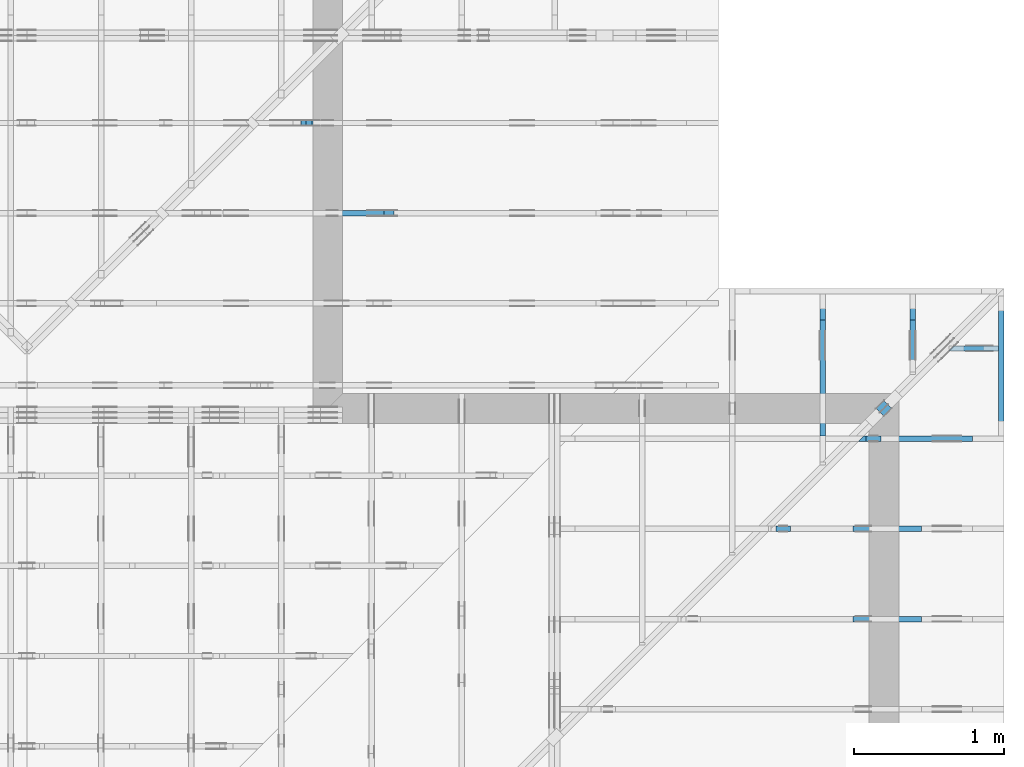
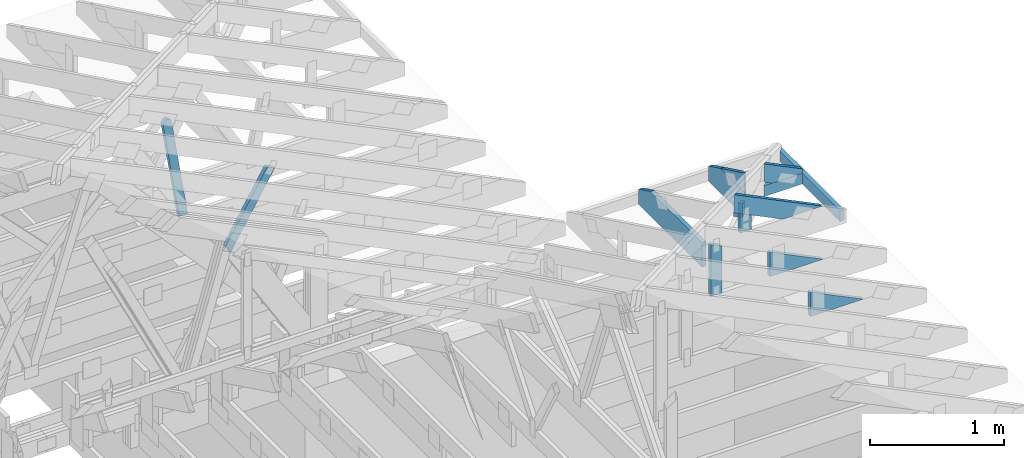
# One storey, part 51 of 159: 15 members, 10 elements without a shape of their own.
"""IFC2X3 building model written with IfcOpenShell, lengths in millimetres."""

from ifc_helpers import new_model, si_unit, frame, origin, origin_with_axes, origin_2d, place, context, project, spatial, faceted_brep, element, aggregate, save


model = new_model("IFC2X3")

# Units and contexts
model_context = context("Model", 3, precision=1e-05, world=origin())
plan_context = context("Plan", 2, precision=1e-05, world=origin_2d())
ifc_project = project(units=[si_unit("LENGTHUNIT", "METRE", prefix="MILLI"), si_unit("AREAUNIT", "SQUARE_METRE"), si_unit("VOLUMEUNIT", "CUBIC_METRE"), si_unit("SOLIDANGLEUNIT", "STERADIAN"), si_unit("PLANEANGLEUNIT", "RADIAN"), si_unit("MASSUNIT", "GRAM"), si_unit("TIMEUNIT", "SECOND"), si_unit("THERMODYNAMICTEMPERATUREUNIT", "DEGREE_CELSIUS"), si_unit("LUMINOUSINTENSITYUNIT", "LUMEN")], contexts=[model_context, plan_context])

# Site, building, storey
site_placement = place(None, origin_with_axes())
site = spatial("IfcSite", under=ifc_project, at=site_placement, CompositionType="ELEMENT")
building_placement = place(site_placement, origin_with_axes())
building = spatial("IfcBuilding", under=site, at=building_placement, Name="Plan 1", CompositionType="ELEMENT")
storey_placement = place(building_placement, origin_with_axes())
storey = spatial("IfcBuildingStorey", under=building, at=storey_placement, Name="Etasje 1", CompositionType="ELEMENT", Elevation=0.0)

# Assembly, member
assembly_1_placement = place(storey_placement, frame((19875.02226140475, 9663.999999999993, 1.1021457184401395e-15), z_axis=(-1.0, 1.836909530733566e-16, 6.123031769111886e-17), x_axis=(-1.836909530733566e-16, -1.0, 0.0)))
assembly_1 = element("IfcElementAssembly", 1, at=assembly_1_placement, inside=storey, Name="S22 (57)", AssemblyPlace="FACTORY", PredefinedType="TRUSS")
member_1_placement = place(assembly_1_placement, frame((946.00634765625, 223.00000000000128, -36.0), z_axis=(0.0, 0.0, 1.0), x_axis=(-1.0, -1.6538962040180127e-15, 0.0)))
member_1 = element("IfcMember", 2, at=member_1_placement, Name="S22-U22", context=model_context, shape_type="Brep", body=[
    faceted_brep([(946.0063476562614, 222.99999999999972, 36.0), (3.410605131648481e-13, 222.99999999999972, 36.0), (0.0, 1.2789769243681803e-12, 36.0), (770.8250579833984, 1.2789769243681803e-12, 36.0), (946.0063476567235, 85.44161987304659, 36.0), (3.410605131648481e-13, 222.99999999999972, 4.176648714595935e-29), (946.0063476562614, 222.99999999999972, 1.1584853840961584e-13), (946.0063476567235, 85.44161987304659, 1.1584853840967244e-13), (770.8250579833984, 1.2789769243681803e-12, 9.439572636919721e-14), (0.0, 1.2789769243681803e-12, 0.0), (1.6105968825286254e-05, 1.2789769243681803e-12, 0.0), (1.6105968827490546e-05, 1.2789769243681803e-12, 36.0), (1.610596915189495e-05, 223.00000000000128, 36.0), (1.6105969149690657e-05, 223.00000000000128, 1.0198588987734166e-30), (770.8250519745052, -2.3187699041427654e-13, 1.4197901788326666e-29), (770.8250519745052, -2.2967269897739626e-13, 36.0), (1.6105968825286254e-05, 1.2811812109601176e-12, 36.0), (1.6105968825286254e-05, 1.2789769195232373e-12, 2.9665740723479956e-37), (946.0063476567235, 85.44162681233115, 0.0), (946.0063476567235, 85.44162681233115, 36.0), (770.8250519745052, 0.0, 36.0), (770.8250519745052, 0.0, 0.0), (946.0063476570106, 222.99999999999972, 4.5880150247654047e-26), (946.0063476570106, 222.99999999999972, 36.0), (946.0063476570106, 85.4416268123311, 36.0), (946.0063476570106, 85.4416268123311, 1.758213185556591e-26), (1.6105969166346767e-05, 223.00000000000128, 0.0), (1.6105969166346767e-05, 223.00000000000128, 36.0), (946.0063476562614, 222.99999999999974, 36.0), (946.0063476562614, 222.99999999999974, 3.1554436208840472e-30)], [[[0, 1, 2, 3, 4]], [[5, 6, 7, 8, 9]], [[10, 11, 12, 13]], [[14, 15, 16, 17]], [[18, 19, 20, 21]], [[22, 23, 24, 25]], [[26, 27, 28, 29]]]),
])
aggregate(assembly_1, [member_1])

# Assembly, members
assembly_2_placement = place(storey_placement, frame((21100.012663101486, 8717.993668449257, 1.1021457184401395e-15), z_axis=(1.2246063538223773e-16, 1.0, 6.123031769111886e-17), x_axis=(-1.0, 1.2246063538223773e-16, 0.0)))
assembly_2 = element("IfcElementAssembly", 3, at=assembly_2_placement, inside=storey, Name="S20 (50)", AssemblyPlace="FACTORY", PredefinedType="TRUSS")
member_2_placement = place(assembly_2_placement, frame((276.0602227100099, 89.9784794737929, -36.00000021758839), z_axis=(0.0, 0.0, 1.0), x_axis=(0.8987940462991673, 0.43837114678907685, 0.0)))
member_2 = element("IfcMember", 4, at=member_2_placement, Name="S20-O72", context=model_context, shape_type="Brep", body=[
    faceted_brep([(841.0306585374396, 148.00000083082764, 2.2533564560944797e-06), (800.9769915401068, 147.99999513788586, 35.99999718740537), (728.7925675890326, 3.2117611681314884e-07, 36.000000217588365), (768.8462375315603, -2.842170943040401e-14, 0.0), (9.503312412562082e-07, 148.00000032044463, 2.175883935251477e-07), (9.503312412562082e-07, 148.00000032044468, 36.00000021758839), (800.976990696425, 148.00000032044463, 36.00000021758839), (841.0306596722551, 148.00000032044457, 2.175883935251477e-07), (303.4449717131315, 3.214784669580695e-07, 2.175883935251477e-07), (303.4449717131315, 3.214784669580695e-07, 36.00000021758839), (0.0, 148.0000018624185, 36.00000021758839), (0.0, 148.0000018624185, 2.175883935251477e-07), (768.8462374461058, 3.2114769473222233e-07, 2.175883935251477e-07), (728.7925684702757, 3.211476403451642e-07, 36.00000021758839), (303.44496181134, 3.2114771847767144e-07, 36.00000021758839), (303.44496181134, 3.211477802222262e-07, 2.175883935251477e-07), (800.9769929430363, 148.00000032117617, 36.00000021758839), (2.6085126251018664e-05, 148.00000032117617, 36.00000021758839), (303.44497237418864, 3.214784953797789e-07, 36.00000021758839), (728.7925675890325, 3.214784953797789e-07, 36.00000021758839), (2.090506382046442e-05, 148.00000032081005, 2.1758839352515026e-07), (841.0306605535013, 148.00000032081005, 2.1758849651829676e-07), (768.8462351994974, 3.2042640896179364e-07, 2.1758848767854618e-07), (303.4449671941263, 3.2042640896179364e-07, 2.1758843068521117e-07)], [[[0, 1, 2, 3]], [[4, 5, 6, 7]], [[8, 9, 10, 11]], [[12, 13, 14, 15]], [[16, 17, 18, 19]], [[20, 21, 22, 23]]]),
])
member_3_placement = place(assembly_2_placement, frame((819.0946433071513, 402.6318664550781, -36.0), z_axis=(0.0, 0.0, 1.0), x_axis=(-1.836909530733566e-16, -1.0, 0.0)))
member_3 = element("IfcMember", 5, at=member_3_placement, Name="S20-S13", context=model_context, shape_type="Brep", body=[
    faceted_brep([(179.63186645507812, 98.00002222019259, 36.0), (0.0, 98.00002222019259, 36.0), (47.79779052734375, 2.2220192477107048e-05, 36.0), (179.63186645507815, 2.2220192477107048e-05, 36.0), (0.0, 98.00002222019259, 0.0), (179.63186645507812, 98.00002222019259, 2.1997832500986142e-14), (179.63186645507815, 2.2220192477107048e-05, 2.1997832500986145e-14), (47.79779052734375, 2.2220192477107048e-05, 5.853347797845619e-15), (47.79780298576225, 7.105427357601002e-15, -4.589974164178181e-31), (47.79780298576226, 7.105427357601002e-15, 36.0), (9.306313593526738e-06, 98.0, 36.0), (9.306313593526738e-06, 98.0, -1.2300741234140647e-31), (179.63186645643037, 8.533005989237634e-14, 1.7362945151808217e-30), (179.63186645643037, 8.753435132925662e-14, 36.0), (47.797802985762246, -5.3410940603069815e-15, 36.0), (47.797802985762246, -7.54538549718726e-15, 4.62006351094737e-31), (179.63186645643037, 98.00000000000011, 3.74235613436848e-27), (179.63186645643037, 98.00000000000011, 36.0), (179.63186645643037, 1.1368683772161603e-13, 36.0), (179.63186645643037, 1.1368683772161603e-13, 0.0), (9.306313586421311e-06, 98.0, 0.0), (9.306313586421311e-06, 98.0, 36.0), (179.63186645636927, 98.00000000000014, 36.0), (179.63186645636927, 98.00000000000014, 2.3665827156630354e-30)], [[[0, 1, 2, 3]], [[4, 5, 6, 7]], [[8, 9, 10, 11]], [[12, 13, 14, 15]], [[16, 17, 18, 19]], [[20, 21, 22, 23]]]),
])
aggregate(assembly_2, [member_2, member_3])

assembly_3_placement = place(storey_placement, frame((21100.012663101486, 8117.993668449257, 1.1021457184401395e-15), z_axis=(1.2246063538223773e-16, 1.0, 6.123031769111886e-17), x_axis=(-1.0, 1.2246063538223773e-16, 0.0)))
assembly_3 = element("IfcElementAssembly", 6, at=assembly_3_placement, inside=storey, Name="S19 (48)", AssemblyPlace="FACTORY", PredefinedType="TRUSS")
member_4_placement = place(assembly_3_placement, frame((1419.0946044921875, 695.2714233398438, -36.0), z_axis=(0.0, 0.0, 1.0), x_axis=(-1.836909530733566e-16, -1.0, 0.0)))
member_4 = element("IfcMember", 7, at=member_4_placement, Name="S19-S12", context=model_context, shape_type="Brep", body=[
    faceted_brep([(472.2714233398437, 98.00000000000023, 36.0), (0.0, 98.00000000000023, 36.0), (47.79779052734375, 0.0, 36.0), (472.27142333984375, 0.0, 36.0), (0.0, 98.00000000000023, 0.0), (472.2714233398437, 98.00000000000023, 5.783465857507103e-14), (472.27142333984375, 0.0, 5.783465857507104e-14), (47.79779052734375, 0.0, 5.853347797845619e-15), (47.79780672964263, 3.881493467261521e-05, -3.298635912486026e-31), (47.79780672964263, 3.881493467261521e-05, 36.0), (1.3050230364797244e-05, 98.0000388149347, 36.0), (1.3050230364797244e-05, 98.0000388149347, -2.6380058583774947e-30), (472.271423340822, 3.8814963997453706e-05, 1.722360653898274e-31), (472.271423340822, 3.8814963999658e-05, 36.0), (47.797806729642616, 3.8814934670982096e-05, 36.0), (47.797806729642616, 3.8814934668777804e-05, 1.7431922945858063e-32), (472.271423340822, 98.000038814964, 3.74235613436848e-27), (472.271423340822, 98.000038814964, 36.0), (472.271423340822, 3.881496400026663e-05, 36.0), (472.271423340822, 3.881496400026663e-05, 0.0), (1.3050230336375533e-05, 98.00003881493467, 0.0), (1.3050230336375533e-05, 98.00003881493467, 36.0), (472.271423340761, 98.0000388149641, 36.0), (472.271423340761, 98.00003881496411, 6.310887241768095e-30)], [[[0, 1, 2, 3]], [[4, 5, 6, 7]], [[8, 9, 10, 11]], [[12, 13, 14, 15]], [[16, 17, 18, 19]], [[20, 21, 22, 23]]]),
])
member_5_placement = place(assembly_3_placement, frame((1006.0125131955604, 446.0, -36.0), z_axis=(0.0, 0.0, 1.0), x_axis=(-1.0, 1.2246063538223773e-16, 0.0)))
member_5 = element("IfcMember", 8, at=member_5_placement, Name="S19-KI3", context=model_context, shape_type="Brep", body=[
    faceted_brep([(9.885291092359694e-07, 223.0, 36.0), (9.885291092359694e-07, 0.0, 36.0), (457.2177744260291, 223.00000000000006, 36.0), (9.885291092359694e-07, 223.0, 0.0), (457.2177744260291, 223.00000000000006, 0.0), (9.885291092359694e-07, 0.0, 0.0), (0.0, 0.0, 0.0), (2.204291436880279e-15, -2.6993892992798474e-31, 36.0), (2.951301312711929e-14, 223.0, 36.0), (2.7308721690239013e-14, 223.0, -1.6721217048316832e-30), (457.2177566712957, 223.00000000000003, 4.7433301404634286e-30), (457.2177566712957, 223.00000000000003, 36.0), (-9.662977650440665e-16, 1.9812040197754925e-15, 36.0), (0.0, 0.0, 0.0), (0.0, 223.0, 0.0), (0.0, 223.0, 36.0), (457.2177566712956, 223.00000000000009, 36.0), (457.2177566712956, 223.00000000000009, 1.5777218104420236e-30)], [[[0, 1, 2]], [[3, 4, 5]], [[6, 7, 8, 9]], [[10, 11, 12, 13]], [[14, 15, 16, 17]]]),
])
aggregate(assembly_3, [member_4, member_5])

# Assembly, member
assembly_4_placement = place(storey_placement, frame((21100.012663101486, 7517.993668449257, 1.1021457184401395e-15), z_axis=(1.2246063538223773e-16, 1.0, 6.123031769111886e-17), x_axis=(-1.0, 1.2246063538223773e-16, 0.0)))
assembly_4 = element("IfcElementAssembly", 9, at=assembly_4_placement, inside=storey, Name="S18 (46)", AssemblyPlace="FACTORY", PredefinedType="TRUSS")
member_6_placement = place(assembly_4_placement, frame((1006.0125131961968, 446.0, -36.0), z_axis=(0.0, 0.0, 1.0), x_axis=(-1.0, 1.2246063538223773e-16, 0.0)))
member_6 = element("IfcMember", 10, at=member_6_placement, Name="S18-KI3", context=model_context, shape_type="Brep", body=[
    faceted_brep([(9.89165528153535e-07, 223.0, 36.0), (9.89165528153535e-07, 0.0, 36.0), (457.2177744266655, 223.00000000000006, 36.0), (9.89165528153535e-07, 223.0, 0.0), (457.2177744266655, 223.00000000000006, 0.0), (9.89165528153535e-07, 0.0, 0.0), (0.0, 0.0, 0.0), (2.204291436880279e-15, -2.6993892992798474e-31, 36.0), (2.951301312711929e-14, 223.0, 36.0), (2.7308721690239013e-14, 223.0, -1.6721217048316832e-30), (457.2177566719321, 222.99999999999977, 2.0500218826610713e-29), (457.2177566719321, 222.99999999999977, 36.0), (-9.662977650429789e-16, 1.9812040197760223e-15, 36.0), (0.0, 0.0, 0.0), (0.0, 223.0, 0.0), (0.0, 223.0, 36.0), (457.217756671932, 223.00000000000009, 36.0), (457.217756671932, 223.00000000000009, 1.5777218104420236e-30)], [[[0, 1, 2]], [[3, 4, 5]], [[6, 7, 8, 9]], [[10, 11, 12, 13]], [[14, 15, 16, 17]]]),
])
aggregate(assembly_4, [member_6])

# Assembly, members
assembly_5_placement = place(storey_placement, frame((21074.556818978763, 9725.45584412271, 2.204291436880279e-15), z_axis=(-0.7071067811865471, 0.7071067811865479, 6.123031769111886e-17), x_axis=(-0.7071067811865479, -0.7071067811865471, 0.0)))
assembly_5 = element("IfcElementAssembly", 11, at=assembly_5_placement, inside=storey, Name="GR1 (36)", AssemblyPlace="FACTORY", PredefinedType="TRUSS")
member_7_placement = place(assembly_5_placement, frame((1093.4566363361005, 353.3163288766036, -36.0), z_axis=(0.0, 0.0, 1.0), x_axis=(-1.836909530733566e-16, -1.0, 0.0)))
member_7 = element("IfcMember", 12, at=member_7_placement, Name="GR1-D75", context=model_context, shape_type="Brep", body=[
    faceted_brep([(130.31632887660362, 73.00002870296203, 36.0), (1.4179337995301466e-05, 73.00002870296203, 36.0), (25.176161640275495, 2.870296202672762e-05, 36.0), (130.31632887660365, 2.870296202672762e-05, 36.0), (1.4179337995301466e-05, 73.00002870296203, 1.7364107402041225e-21), (130.31632887660362, 73.00002870296203, 1.5958620434909532e-14), (130.31632887660365, 2.870296202672762e-05, 1.5958620434909535e-14), (25.176161640275495, 2.870296202672762e-05, 3.0830887509540575e-15), (25.17616851694908, 0.0, -1.9721522630525295e-31), (25.176168516949083, 8.881784197001252e-16, 36.0), (1.7763568394002505e-14, 73.00000000000001, 36.0), (1.4210854715202004e-14, 73.00000000000001, -9.860761315262648e-31), (130.31632887660365, -2.3937930652364306e-14, 1.4657270987122386e-30), (130.31632887660365, -2.1733639215484027e-14, 36.0), (25.176168516949076, -2.4203429527335313e-15, 36.0), (25.176168516949076, -4.62463438961381e-15, 2.831678328813272e-31), (130.31632887660365, 73.0, 1.5777218104420236e-30), (130.31632887660365, 73.0, 36.0), (130.31632887660365, 0.0, 36.0), (130.31632887660365, 0.0, 0.0), (0.0, 73.0, 0.0), (-1.3496946496399237e-31, 73.0, 36.0), (130.31632887660362, 72.99999999999999, 36.0), (130.31632887660362, 72.99999999999999, -7.888609052210118e-31)], [[[0, 1, 2, 3]], [[4, 5, 6, 7]], [[8, 9, 10, 11]], [[12, 13, 14, 15]], [[16, 17, 18, 19]], [[20, 21, 22, 23]]]),
])
member_8_placement = place(assembly_5_placement, frame((1093.4566363361005, 353.3163288766036, -72.0), z_axis=(0.0, 0.0, 1.0), x_axis=(-1.836909530733566e-16, -1.0, 0.0)))
member_8 = element("IfcMember", 13, at=member_8_placement, Name="GR1-D75", context=model_context, shape_type="Brep", body=[
    faceted_brep([(130.31632887660362, 73.00002870296203, 36.0), (1.4179337995301466e-05, 73.00002870296203, 36.0), (25.176161640275495, 2.870296202672762e-05, 36.0), (130.31632887660365, 2.870296202672762e-05, 36.0), (1.4179337995301466e-05, 73.00002870296203, 1.7364107402041225e-21), (130.31632887660362, 73.00002870296203, 1.5958620434909532e-14), (130.31632887660365, 2.870296202672762e-05, 1.5958620434909535e-14), (25.176161640275495, 2.870296202672762e-05, 3.0830887509540575e-15), (25.17616851694908, 0.0, -1.9721522630525295e-31), (25.176168516949083, 8.881784197001252e-16, 36.0), (1.7763568394002505e-14, 73.00000000000001, 36.0), (1.4210854715202004e-14, 73.00000000000001, -9.860761315262648e-31), (130.31632887660365, -2.3937930652364306e-14, 1.4657270987122386e-30), (130.31632887660365, -2.1733639215484027e-14, 36.0), (25.176168516949076, -2.4203429527335313e-15, 36.0), (25.176168516949076, -4.62463438961381e-15, 2.831678328813272e-31), (130.31632887660365, 73.0, 1.5777218104420236e-30), (130.31632887660365, 73.0, 36.0), (130.31632887660365, 0.0, 36.0), (130.31632887660365, 0.0, 0.0), (0.0, 73.0, 0.0), (-1.3496946496399237e-31, 73.0, 36.0), (130.31632887660362, 72.99999999999999, 36.0), (130.31632887660362, 72.99999999999999, -7.888609052210118e-31)], [[[0, 1, 2, 3]], [[4, 5, 6, 7]], [[8, 9, 10, 11]], [[12, 13, 14, 15]], [[16, 17, 18, 19]], [[20, 21, 22, 23]]]),
])
aggregate(assembly_5, [member_7, member_8])

# Assembly, member
assembly_6_placement = place(storey_placement, frame((19200.01266310149, 10817.999978540158, 1.1021457184401395e-15), z_axis=(1.2246063538223773e-16, 1.0, 6.123031769111886e-17), x_axis=(-1.0, 1.2246063538223773e-16, 0.0)))
assembly_6 = element("IfcElementAssembly", 14, at=assembly_6_placement, inside=storey, Name="V10 (59)", AssemblyPlace="FACTORY", PredefinedType="TRUSS")
member_9_placement = place(assembly_6_placement, frame((2707.982202579169, 1299.3603042752206, -36.0), z_axis=(0.0, 0.0, 1.0), x_axis=(-0.15528482829789178, -0.9878697394396158, 0.0)))
member_9 = element("IfcMember", 15, at=member_9_placement, Name="V10-D54", context=model_context, shape_type="Brep", body=[
    faceted_brep([(928.284833061482, 73.00010076503486, 36.0), (27.46336535971227, 73.00010076503486, 36.0), (8.974104503067792e-06, 36.50010538441802, 36.0), (25.49436730226512, 0.0001248848125214863, 36.0), (939.7598359494717, 0.0001248848125214863, 36.0), (27.46336535971227, 73.00010076503486, 3.3631811716849025e-15), (928.284833061482, 73.00010076503486, 1.1367835047240357e-13), (939.7598359494717, 0.0001248848125214863, 1.150835866170798e-13), (25.49436730226512, 0.0001248848125214863, 3.1220564185035324e-15), (8.974104503067792e-06, 36.50010538441802, 1.0989745394322826e-21), (0.0, 36.500050381629535, 1.797500255896325e-31), (0.0, 36.500050381629535, 36.0), (27.463373840749675, 73.00005038245719, 36.0), (27.463373840749675, 73.00005038245719, 6.584781484801848e-31), (25.494317790369458, 5.038245763167026e-05, -3.944304526105059e-31), (25.494317790369458, 5.038245763344662e-05, 36.0), (3.552713678800501e-15, 36.500050381629535, 36.0), (0.0, 36.500050381629535, -1.9721522630525295e-31), (939.7598280290655, 5.038245988520787e-05, 2.897235810720277e-29), (939.7598280290655, 5.038245988741216e-05, 36.0), (25.49431779036945, 5.038245761926178e-05, 36.0), (25.49431779036945, 5.038245761705749e-05, 7.859784049936994e-31), (928.2848409805019, 73.000050382459, 1.1098596764440826e-31), (928.2848409805019, 73.000050382459, 36.0), (939.7598280290655, 5.038246038679972e-05, 36.0), (939.7598280290655, 5.038246038679972e-05, 2.2484137211910448e-31), (27.463373840749686, 73.00005038245718, -7.888609052210118e-31), (27.463373840749686, 73.00005038245718, 36.0), (928.2848409805019, 73.00005038245891, 36.0), (928.2848409805019, 73.00005038245892, -4.733165431326071e-30)], [[[0, 1, 2, 3, 4]], [[5, 6, 7, 8, 9]], [[10, 11, 12, 13]], [[14, 15, 16, 17]], [[18, 19, 20, 21]], [[22, 23, 24, 25]], [[26, 27, 28, 29]]]),
])
aggregate(assembly_6, [member_9])

assembly_7_placement = place(storey_placement, frame((19200.01266310149, 10217.999978540158, 1.1021457184401395e-15), z_axis=(1.2246063538223773e-16, 1.0, 6.123031769111886e-17), x_axis=(-1.0, 1.2246063538223773e-16, 0.0)))
assembly_7 = element("IfcElementAssembly", 16, at=assembly_7_placement, inside=storey, Name="V11 (60)", AssemblyPlace="FACTORY", PredefinedType="TRUSS")
member_10_placement = place(assembly_7_placement, frame((2159.357056377413, 1008.523719555199, -36.0), z_axis=(0.0, 0.0, 1.0), x_axis=(0.5136499122987088, -0.8579998645661483, 0.0)))
member_10 = element("IfcMember", 17, at=member_10_placement, Name="V11-D65", context=model_context, shape_type="Brep", body=[
    faceted_brep([(706.2039179412637, 73.00004546544824, 36.0), (6.267613154616697, 73.00004546544824, 36.0), (4.2497536469454644e-05, 0.00011600014249779633, 36.0), (743.0347823511636, 0.00011600014249779633, 36.0), (6.267613154616697, 73.00004546544824, 7.675358892444321e-16), (706.2039179412637, 73.00004546544824, 8.648218050051283e-14), (743.0347823511636, 0.00011600014249779633, 9.099251155782621e-14), (4.2497536469454644e-05, 0.00011600014249779633, 5.2042753182292355e-21), (0.0, 0.0, 0.0), (2.1962115429144702e-15, -1.8856191946670405e-16, 36.0), (6.267620332603614, 73.00000000000047, 36.0), (6.267620332603612, 73.00000000000047, 2.711709361697228e-30), (743.0347554630055, 1.1834061073811744e-12, 3.891696714333197e-29), (743.0347554630055, 1.1856103988180547e-12, 36.0), (-3.510699775041712e-30, 2.204291436880279e-15, 36.0), (0.0, 0.0, 0.0), (706.20389085637, 73.00000000000139, 0.0), (706.20389085637, 73.00000000000139, 36.0), (743.0347554630056, 1.8758328224066645e-12, 36.0), (743.0347554630056, 1.8758328224066645e-12, 6.310887241768095e-30), (6.267620332603655, 73.00000000000045, 0.0), (6.267620332603655, 73.00000000000044, 36.0), (706.2038908563699, 73.00000000000134, 36.0), (706.2038908563699, 73.00000000000134, -1.5777218104420236e-30)], [[[0, 1, 2, 3]], [[4, 5, 6, 7]], [[8, 9, 10, 11]], [[12, 13, 14, 15]], [[16, 17, 18, 19]], [[20, 21, 22, 23]]]),
])
aggregate(assembly_7, [member_10])

# Assembly, members
assembly_8_placement = place(storey_placement, frame((20475.02226140475, 9663.999999999289, 1.1021457184401395e-15), z_axis=(-1.0, -3.9144503800490546e-11, 6.123031769111886e-17), x_axis=(3.9144503800490546e-11, -1.0, 0.0)))
assembly_8 = element("IfcElementAssembly", 18, at=assembly_8_placement, inside=storey, Name="S21 (1)", AssemblyPlace="FACTORY", PredefinedType="TRUSS")
member_11_placement = place(assembly_8_placement, frame((240.06021530352973, 89.97847588598879, -36.00000002886254), z_axis=(0.0, 0.0, 1.0), x_axis=(0.898794046299167, 0.4383711467890774, 0.0)))
member_11 = element("IfcMember", 19, at=member_11_placement, Name="S21-O78", context=model_context, shape_type="Brep", body=[
    faceted_brep([(403.760380001694, 148.00000170526982, 35.99999710778698), (331.5759589978774, -2.1316282072803006e-14, 35.99999974632871), (303.4449799428221, 2.9938888701508404e-07, 10.716043121688841), (293.8134641859805, 4.697604411286115, -2.842170943040401e-14), (363.7067130055062, 147.9999960106528, 2.1724640362208447e-06), (6.6138661622971995e-06, 148.0000003003606, 2.8862537249096928e-08), (6.6138661622971995e-06, 148.00000030036063, 36.00000002886254), (403.76038259042866, 148.0000003003606, 36.00000002886254), (363.7067136145986, 148.00000030036057, 2.8862537249096928e-08), (363.70671271272136, 148.0000003002788, 2.886253724909693e-08), (293.8134632010026, 4.697601618638174, 2.886253724909693e-08), (1.715608067343055e-05, 148.0000002995364, 2.886253724909693e-08), (303.4449802846992, 1.3264404685742193e-07, 10.716043501152575), (303.4449802846992, 1.3264407527913136e-07, 36.000000028862544), (3.552713678800501e-14, 148.00000585421736, 36.000000028862544), (2.1316282072803006e-14, 148.00000585421733, 2.886253724909693e-08), (293.81346421192194, 4.697604398633445, 2.886253724909693e-08), (303.444979942822, 2.9938891543679347e-07, 10.716043121688859), (331.57595948078585, 2.9938891543679347e-07, 35.999999649398816), (303.444979942822, 2.9938891543679347e-07, 35.999999649398816), (403.7603848362204, 148.00000029940784, 36.00000002886254), (1.2302633649596828e-06, 148.00000029940784, 36.00000002886254), (303.4449799442526, 2.993888585933746e-07, 36.00000002886254), (331.5759594822165, 2.993888585933746e-07, 36.00000002886254)], [[[0, 1, 2, 3, 4]], [[5, 6, 7, 8]], [[9, 10, 11]], [[12, 13, 14, 15, 16]], [[17, 18, 19]], [[20, 21, 22, 23]]]),
])
member_12_placement = place(assembly_8_placement, frame((538.0787353510889, 223.0000006901114, -36.00000168118806), z_axis=(0.0, 0.0, 1.0), x_axis=(-1.0, -2.542074623718138e-15, 0.0)))
member_12 = element("IfcMember", 20, at=member_12_placement, Name="S21-U30", context=model_context, shape_type="Brep", body=[
    faceted_brep([(36.000022979249124, 6.901113076874792e-07, 6.20676804174991e-07), (2.190023906578631e-05, 6.901113920321223e-07, 36.00000168118775), (2.1900239342897976e-05, 223.00000069011136, 36.000001681187996), (36.00002297924908, 223.0000006901113, 6.206773761618933e-07), (362.8974523201613, 6.901113253711434e-07, 1.6811880598766038e-06), (362.8974523201613, 6.901113275754349e-07, 36.00000168118806), (2.190023940329411e-05, 6.901113942364098e-07, 36.00000168118806), (36.0000219002394, 6.90111385419244e-07, 1.6811880598766038e-06), (36.00002191874131, 223.0000006901113, 1.6811880642851894e-06), (538.0787267527251, 223.0000006901113, 1.6811881257700666e-06), (538.0787267527251, 85.44162819255271, 1.6811881257700666e-06), (362.89745233866256, 6.901104825374205e-07, 1.6811881043172563e-06), (36.000021918740686, 6.901104825374205e-07, 1.6811880642851894e-06), (2.1918741254012275e-05, 223.0000006901113, 36.00000168118806), (538.0787267527257, 223.00000069011128, 36.00000168118806), (538.0787267527257, 223.00000069011128, 1.6811880598766038e-06), (36.00002191874131, 223.0000006901113, 1.6811880598766038e-06), (538.0787353515626, 85.44162750244115, 1.6811880598766038e-06), (538.0787353515626, 85.44162750244115, 36.00000168118806), (362.89744511097285, 3.344169613228587e-06, 36.00000168118806), (362.89744511097285, 3.344169613228587e-06, 1.6811880598766038e-06), (538.0787353518494, 223.0000006641036, 1.110461326447876e-06), (538.0787353518494, 223.0000006641036, 36.00000168118806), (538.0787353518494, 85.44162308057733, 36.00000226088839), (538.0787353518494, 85.44162308057733, 1.7569510081082375e-26), (538.0787353511005, 223.00000762939453, 36.00000168118806), (0.0, 223.00000762939453, 36.00000168118806), (0.0, 0.0, 36.00000168118806), (362.89744567871094, 0.0, 36.00000168118806), (538.0787353515625, 85.4416275024414, 36.00000168118806)], [[[0, 1, 2, 3]], [[4, 5, 6, 7]], [[8, 9, 10, 11, 12]], [[13, 14, 15, 16]], [[17, 18, 19, 20]], [[21, 22, 23, 24]], [[25, 26, 27, 28, 29]]]),
])
aggregate(assembly_8, [member_11, member_12])

# Assembly, member
assembly_9_placement = place(storey_placement, frame((21100.012663101486, 8717.993668449257, 0.0), z_axis=(1.0, 5.688943592466536e-12, 6.123031769111886e-17), x_axis=(-5.688943592466536e-12, 1.0, 0.0)))
assembly_9 = element("IfcElementAssembly", 21, at=assembly_9_placement, inside=storey, Name="uu4 (1)", AssemblyPlace="FACTORY", PredefinedType="TRUSS")
member_13_placement = place(assembly_9_placement, frame((931.0946655273436, 98.00000236466403, -36.00000106732325), z_axis=(0.0, 0.0, 1.0), x_axis=(-1.0, -1.6538962040180127e-15, 0.0)))
member_13 = element("IfcMember", 22, at=member_13_placement, Name="uu4-U53", context=model_context, shape_type="Brep", body=[
    faceted_brep([(36.00002329423805, 2.364663942909905e-06, -2.842170943040401e-14), (2.2222040456654213e-05, 2.364664027254548e-06, 36.00000106732313), (2.222204057034105e-05, 98.00000236466403, 36.000001067323254), (36.00002329423797, 98.00000236466394, 2.8421709430404007e-13), (931.0946877493843, 2.364663856220878e-06, 1.0673232466729134e-06), (931.0946877493843, 2.364663874412381e-06, 36.00000106732325), (2.222204057034105e-05, 2.3646640454460475e-06, 36.00000106732325), (36.00002222204057, 2.36466402064167e-06, 1.0673232466729134e-06), (36.000022226923306, 98.00000236466397, 1.0673232510814989e-06), (931.0946877542668, 98.00000236466397, 1.0673233606953602e-06), (931.0946877542668, 2.364662492482239e-06, 1.0673233606953602e-06), (36.00002222692308, 2.364662492482239e-06, 1.0673232510814989e-06), (2.2226923306334356e-05, 98.00000236466397, 36.00000106732325), (931.094687754267, 98.00000236466391, 36.00000106732325), (931.094687754267, 98.00000236466391, 1.0673232466729132e-06), (36.000022226923306, 98.00000236466397, 1.0673232466729132e-06), (931.0946655273438, 98.0000023463934, 2.0322914693338134e-06), (931.0946655273438, 98.0000023463934, 36.00000106732325), (931.0946655273438, 0.0, 36.0000028942319), (931.0946655273438, 0.0, 3.5303565582012197e-06), (931.0946655273438, 98.00000236466249, 36.00000106732325), (0.0, 98.00000236466249, 36.00000106732325), (0.0, 2.364664041465403e-06, 36.00000106732325), (931.0946655273438, 2.364664041465403e-06, 36.00000106732325)], [[[0, 1, 2, 3]], [[4, 5, 6, 7]], [[8, 9, 10, 11]], [[12, 13, 14, 15]], [[16, 17, 18, 19]], [[20, 21, 22, 23]]]),
])
aggregate(assembly_9, [member_13])

# Assembly, members
assembly_10_placement = place(storey_placement, frame((21064.012663098183, 9317.993668449257, 1.1021457184401395e-15), z_axis=(1.2246063538223773e-16, 1.0, 6.123031769111886e-17), x_axis=(-1.0, 1.2246063538223773e-16, 0.0)))
assembly_10 = element("IfcElementAssembly", 23, at=assembly_10_placement, inside=storey, Name="S46 (83)", AssemblyPlace="FACTORY", PredefinedType="TRUSS")
member_14_placement = place(assembly_10_placement, frame((49.29270742500094, -3.065054571870509, -36.00000113071811), z_axis=(0.0, 0.0, 1.0), x_axis=(0.8987940462991673, 0.43837114678907735, 0.0)))
member_14 = element("IfcMember", 24, at=member_14_placement, Name="S46-O79", context=model_context, shape_type="Brep", body=[
    faceted_brep([(385.7178019389395, 148.00000082965897, 3.1653045766688592e-06), (345.6641349402792, 147.9999951386597, 35.99999809787677), (273.4797109868087, 3.231186838092981e-07, 36.00000113071816), (313.53338093066384, 7.105427357601002e-15, 9.146066020093713e-07), (17.341258117575194, 148.000000322261, 1.1307181040365322e-06), (17.341258117575194, 148.00000032226095, 36.000001130718104), (345.66413409413775, 148.00000032226092, 36.000001130718104), (385.7178030699678, 148.00000032226097, 1.1307181040365322e-06), (1.239579036393934e-05, 112.44517100936375, 1.2339723411969317e-06), (1.239579036393934e-05, 112.44517100936375, 36.000001130718104), (17.34126163509928, 148.00000094250768, 36.000000859565915), (17.34126163509928, 148.00000094250768, 1.9721522630525295e-30), (230.5467753100797, 3.23396719181801e-07, 1.1307181040365322e-06), (230.5467753100797, 3.23396719181801e-07, 36.000001130718104), (1.319245973974148e-05, 112.4451693965195, 36.000001130718104), (1.319245973974148e-05, 112.44516939651949, 1.1307181040365322e-06), (313.5333808476825, 3.2285923548493594e-07, 1.1307181040365322e-06), (273.47971187185243, 3.228592130723009e-07, 36.000001130718104), (230.54677806447935, 3.2285922095869243e-07, 36.000001130718104), (230.54677806447935, 3.228592507288241e-07, 1.1307181040365322e-06), (345.6641363408125, 148.0000003231187, 36.000001130718104), (17.341252734855452, 148.0000003231187, 36.000001130718104), (5.176261701933527e-06, 112.4451678646226, 36.000001130718104), (230.54677717943557, 3.2339676181436516e-07, 36.000001130718104), (273.47971098680864, 3.2339676181436516e-07, 36.000001130718104), (17.34124755859377, 148.0000003232696, 1.1307181061601524e-06), (385.7178039550782, 148.0000003232696, 1.1307181512717795e-06), (313.5333786010743, 3.221379216711284e-07, 1.130718142432029e-06), (230.5467681884766, 3.221379216711284e-07, 1.1307181322694358e-06), (0.0, 112.44517167833912, 1.1307181040365322e-06)], [[[0, 1, 2, 3]], [[4, 5, 6, 7]], [[8, 9, 10, 11]], [[12, 13, 14, 15]], [[16, 17, 18, 19]], [[20, 21, 22, 23, 24]], [[25, 26, 27, 28, 29]]]),
])
member_15_placement = place(assembly_10_placement, frame((331.0946443734273, 98.00000236466245, -36.000001068008515), z_axis=(0.0, 0.0, 1.0), x_axis=(-1.0, 1.2246063538223773e-16, 0.0)))
member_15 = element("IfcMember", 25, at=member_15_placement, Name="S46-U56", context=model_context, shape_type="Brep", body=[
    faceted_brep([(-2.0097183325385402e-14, 2.3646624542582578e-06, 2.009718332734117e-14), (36.000001071511804, 2.364662449849675e-06, 36.00000106800848), (36.00000107151186, 98.00000236466245, 36.00000106800852), (-6.991184834638701e-15, 98.00000236466245, 2.1202039550521056e-14), (331.09463608127743, 2.364660825836567e-06, 1.0680085154035623e-06), (331.09463608127743, 2.364660812053647e-06, 36.000001068008515), (36.000001071511804, 2.3646608662598618e-06, 36.000001068008515), (1.0715118037296634e-06, 2.3646608866556562e-06, 1.0680085154035623e-06), (1.068011329152796e-06, 98.00000236466245, 1.0680085154035623e-06), (36.00000106801133, 98.00000236466245, 36.000001068008515), (331.09463607777695, 98.00000236466242, 36.000001068008515), (331.09463607777695, 98.00000236466244, 1.0680085154035623e-06), (331.09464437343246, 98.00000234639514, 2.0329767380644626e-06), (331.09464437343246, 98.00000234639514, 36.000001068008515), (331.09464437343246, 0.0, 36.000002894912456), (331.09464437343246, 0.0, 3.531037123138958e-06), (331.0946360812775, 98.00000236466249, 36.000001068008515), (36.00000107151186, 98.00000236466249, 36.000001068008515), (36.000001071511804, 2.364662449849675e-06, 36.000001068008515), (331.0946360812775, 2.364662449849675e-06, 36.000001068008515), (9.363661661154765e-06, 98.00000236466245, 1.0680085154035634e-06), (331.0946443734273, 98.00000236466245, 1.0680085559496228e-06), (331.09464437343246, 2.364662492482239e-06, 1.0680085559496228e-06), (9.363661661154765e-06, 2.364662492482239e-06, 1.0680085154035634e-06)], [[[0, 1, 2, 3]], [[4, 5, 6, 7]], [[8, 9, 10, 11]], [[12, 13, 14, 15]], [[16, 17, 18, 19]], [[20, 21, 22, 23]]]),
])
aggregate(assembly_10, [member_14, member_15])

save(model, "model.ifc")
